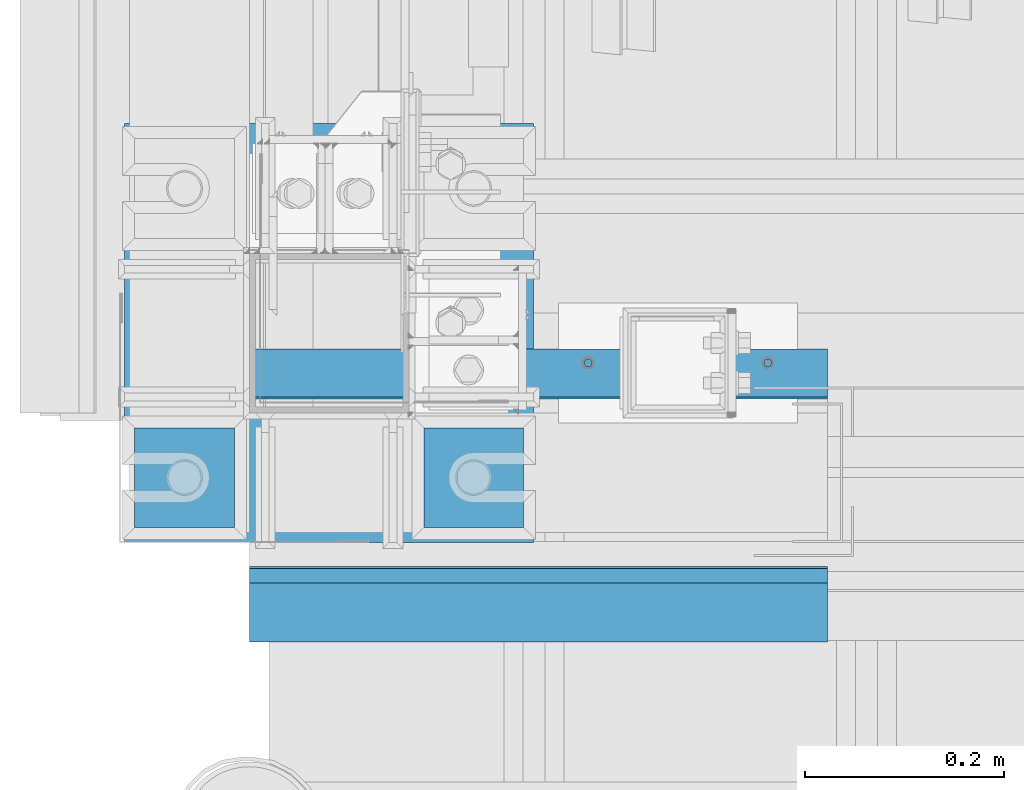
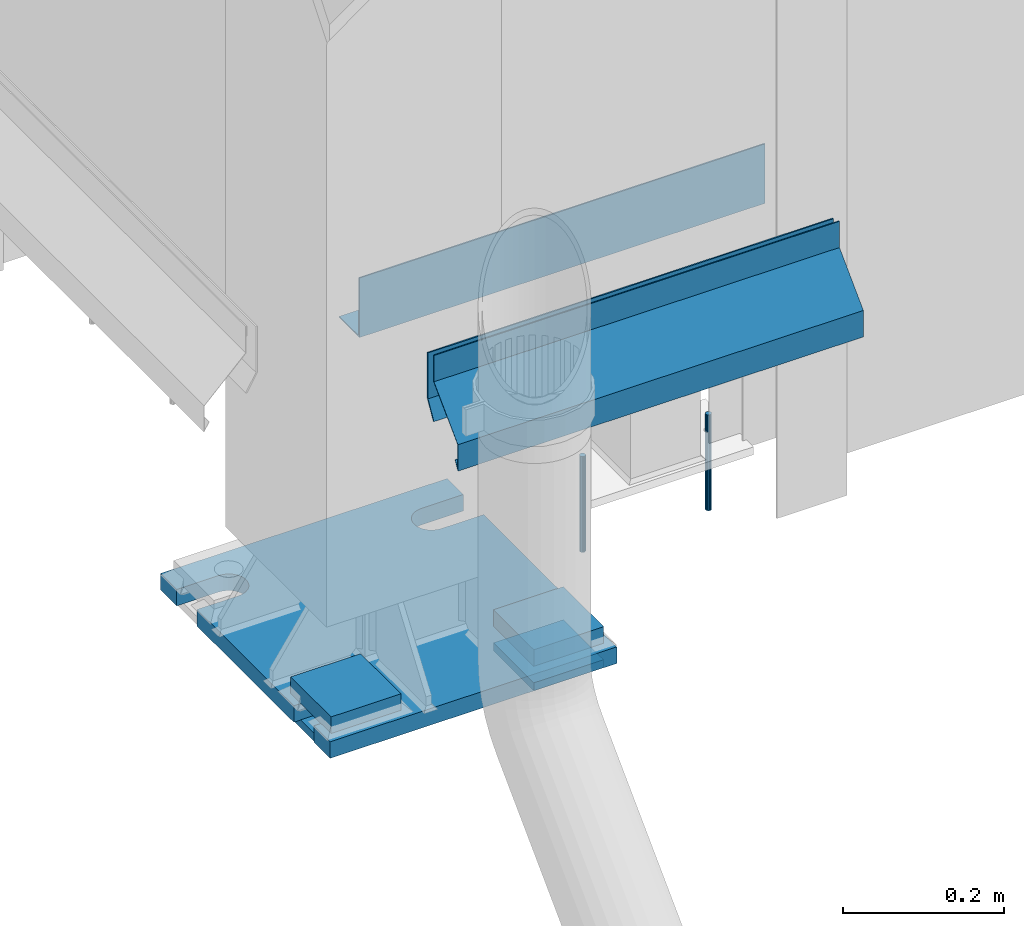
# One storey, part 82 of 709: 10 beams, 4 openings, 10 elements without a shape of their own.
"""IFC4 building model written with IfcOpenShell, lengths in millimetres."""

from ifc_helpers import new_model, si_unit, direction, frame, origin_with_axes, place, context, subcontext, project, spatial, line, arc, indexed_curve, outline, extrude, material, element, aggregate, save


model = new_model("IFC4")

# Units and contexts
model_context = context("Model", 3, precision=0.2, world=origin_with_axes(), true_north=direction((0.0, 1.0)))
body_context = subcontext(model_context, "Body", "Model", "MODEL_VIEW")
ifc_project = project(units=[si_unit("LENGTHUNIT", "METRE", prefix="MILLI"), si_unit("AREAUNIT", "SQUARE_METRE"), si_unit("VOLUMEUNIT", "CUBIC_METRE"), si_unit("MASSUNIT", "GRAM", prefix="KILO"), si_unit("TIMEUNIT", "SECOND"), si_unit("PLANEANGLEUNIT", "RADIAN"), si_unit("SOLIDANGLEUNIT", "STERADIAN"), si_unit("THERMODYNAMICTEMPERATUREUNIT", "DEGREE_CELSIUS"), si_unit("LUMINOUSINTENSITYUNIT", "LUMEN")], contexts=[model_context])

# Site, building, storey
site_placement = place(None, origin_with_axes())
site = spatial("IfcSite", under=ifc_project, at=site_placement, CompositionType="ELEMENT")
building_placement = place(site_placement, origin_with_axes())
building = spatial("IfcBuilding", under=site, at=building_placement, Name="Undefined", CompositionType="ELEMENT")
storey_placement = place(building_placement, origin_with_axes())
storey = spatial("IfcBuildingStorey", under=building, at=storey_placement, Name="Undefined", CompositionType="ELEMENT", Elevation=0.0)

# Assembly, beam, voiding features
assembly_1_placement = place(storey_placement, frame((80.0, 80.0, -200.0), z_axis=(0.0, -1.0, 0.0), x_axis=(0.0, 0.0, 1.0)))
assembly_1 = element("IfcElementAssembly", 1, at=assembly_1_placement, inside=storey)
ifc_material_1 = material(Name="C355-6", Category="STEEL")
beam_1_placement = place(assembly_1_placement, frame((12.5, 205.0, 0.0), z_axis=(-1.0, 0.0, 0.0), x_axis=(0.0, -1.0, 0.0)))
beam_1 = element("IfcBeam", 2, at=beam_1_placement, material=ifc_material_1, ObjectType="428", context=body_context, shape_type="SolidModel", body=[
    extrude(outline(indexed_curve([(-12.5, -210.0), (12.5, -210.0), (12.5, 210.0), (-12.5, 210.0)], segments=[line(1, 2, 3, 4, 1)])), frame((0.0, 0.0, 0.0), z_axis=(-1.0, 0.0, 0.0), x_axis=(0.0, 0.0, 1.0)), (0.0, 0.0, -1.0), 410.0),
])
voiding_feature_1_placement = place(beam_1_placement, frame((410.0, 170.0, 0.0), z_axis=(0.0, 0.0, -1.0), x_axis=(0.0, -1.0, 0.0)))
element("IfcVoidingFeature", 3, at=voiding_feature_1_placement, cuts=beam_1, PredefinedType="HOLE", context=body_context, shape_type="SolidModel", body=[
    extrude(outline(indexed_curve([(0.0, 0.0), (50.0, 0.0), (50.0, 60.0), (42.67767, 77.67767), (25.0, 85.0), (25.0, 85.0), (7.32233, 77.67767), (0.0, 60.0)], segments=[line(1, 2, 3), arc(3, 4, 5), line(5, 6), arc(6, 7, 8), line(8, 1)])), frame((0.0, 0.0, 12.5), z_axis=(0.0, 0.0, 1.0), x_axis=(1.0, 0.0, 0.0)), (0.0, 0.0, -1.0), 25.0),
])
voiding_feature_2_placement = place(beam_1_placement, frame((410.0, -120.0, 0.0), z_axis=(0.0, 0.0, -1.0), x_axis=(0.0, -1.0, 0.0)))
element("IfcVoidingFeature", 4, at=voiding_feature_2_placement, cuts=beam_1, PredefinedType="HOLE", context=body_context, shape_type="SolidModel", body=[
    extrude(outline(indexed_curve([(0.0, 0.0), (50.0, 0.0), (50.0, 60.0), (42.67767, 77.67767), (25.0, 85.0), (25.0, 85.0), (7.32233, 77.67767), (0.0, 60.0)], segments=[line(1, 2, 3), arc(3, 4, 5), line(5, 6), arc(6, 7, 8), line(8, 1)])), frame((0.0, 0.0, 12.5), z_axis=(0.0, 0.0, 1.0), x_axis=(1.0, 0.0, 0.0)), (0.0, 0.0, -1.0), 25.0),
])
voiding_feature_3_placement = place(beam_1_placement, frame((0.0, 120.0, 0.0), z_axis=(0.0, 0.0, -1.0), x_axis=(0.0, 1.0, 0.0)))
element("IfcVoidingFeature", 5, at=voiding_feature_3_placement, cuts=beam_1, PredefinedType="HOLE", context=body_context, shape_type="SolidModel", body=[
    extrude(outline(indexed_curve([(0.0, 0.0), (50.0, 0.0), (50.0, 60.0), (42.67767, 77.67767), (25.0, 85.0), (25.0, 85.0), (7.32233, 77.67767), (0.0, 60.0)], segments=[line(1, 2, 3), arc(3, 4, 5), line(5, 6), arc(6, 7, 8), line(8, 1)])), frame((0.0, 0.0, 12.5), z_axis=(0.0, 0.0, 1.0), x_axis=(1.0, 0.0, 0.0)), (0.0, 0.0, -1.0), 25.0),
])
voiding_feature_4_placement = place(beam_1_placement, frame((0.0, -170.0, 0.0), z_axis=(0.0, 0.0, -1.0), x_axis=(0.0, 1.0, 0.0)))
element("IfcVoidingFeature", 6, at=voiding_feature_4_placement, cuts=beam_1, PredefinedType="HOLE", context=body_context, shape_type="SolidModel", body=[
    extrude(outline(indexed_curve([(0.0, 0.0), (50.0, 0.0), (50.0, 60.0), (42.67767, 77.67767), (25.0, 85.0), (25.0, 85.0), (7.32233, 77.67767), (0.0, 60.0)], segments=[line(1, 2, 3), arc(3, 4, 5), line(5, 6), arc(6, 7, 8), line(8, 1)])), frame((0.0, 0.0, 12.5), z_axis=(0.0, 0.0, 1.0), x_axis=(1.0, 0.0, 0.0)), (0.0, 0.0, -1.0), 25.0),
])
aggregate(assembly_1, [beam_1])

# Assembly, beam
assembly_2_placement = place(storey_placement, frame((175.0, -65.0, -162.5), z_axis=(0.0, 0.0, -1.0), x_axis=(1.0, 0.0, 0.0)))
assembly_2 = element("IfcElementAssembly", 7, at=assembly_2_placement, inside=storey)
beam_2_placement = place(assembly_2_placement, origin_with_axes())
beam_2 = element("IfcBeam", 8, at=beam_2_placement, material=ifc_material_1, ObjectType="421", context=body_context, shape_type="SolidModel", body=[
    extrude(outline(indexed_curve([(-12.5, -50.0), (12.5, -50.0), (12.5, 50.0), (-12.5, 50.0)], segments=[line(1, 2, 3, 4, 1)])), frame((0.0, 0.0, 0.0), z_axis=(-1.0, 0.0, 0.0), x_axis=(0.0, 0.0, 1.0)), (0.0, 0.0, -1.0), 100.0),
])
aggregate(assembly_2, [beam_2])

assembly_3_placement = place(storey_placement, frame((175.0, -65.0, -206.0), z_axis=(0.0, 0.0, -1.0), x_axis=(1.0, 0.0, 0.0)))
assembly_3 = element("IfcElementAssembly", 9, at=assembly_3_placement, inside=storey)
beam_3_placement = place(assembly_3_placement, origin_with_axes())
beam_3 = element("IfcBeam", 10, at=beam_3_placement, material=ifc_material_1, ObjectType="422", context=body_context, shape_type="SolidModel", body=[
    extrude(outline(indexed_curve([(-6.0, -50.0), (6.0, -50.0), (6.0, 50.0), (-6.0, 50.0)], segments=[line(1, 2, 3, 4, 1)])), frame((0.0, 0.0, 0.0), z_axis=(-1.0, 0.0, 0.0), x_axis=(0.0, 0.0, 1.0)), (0.0, 0.0, -1.0), 100.0),
])
aggregate(assembly_3, [beam_3])

assembly_4_placement = place(storey_placement, frame((-115.0, -65.0, -162.5), z_axis=(0.0, 0.0, -1.0), x_axis=(1.0, 0.0, 0.0)))
assembly_4 = element("IfcElementAssembly", 11, at=assembly_4_placement, inside=storey)
beam_4_placement = place(assembly_4_placement, origin_with_axes())
beam_4 = element("IfcBeam", 12, at=beam_4_placement, material=ifc_material_1, ObjectType="421", context=body_context, shape_type="SolidModel", body=[
    extrude(outline(indexed_curve([(-12.5, -50.0), (12.5, -50.0), (12.5, 50.0), (-12.5, 50.0)], segments=[line(1, 2, 3, 4, 1)])), frame((0.0, 0.0, 0.0), z_axis=(-1.0, 0.0, 0.0), x_axis=(0.0, 0.0, 1.0)), (0.0, 0.0, -1.0), 100.0),
])
aggregate(assembly_4, [beam_4])

assembly_5_placement = place(storey_placement, frame((-115.0, -65.0, -206.0), z_axis=(0.0, 0.0, -1.0), x_axis=(1.0, 0.0, 0.0)))
assembly_5 = element("IfcElementAssembly", 13, at=assembly_5_placement, inside=storey)
beam_5_placement = place(assembly_5_placement, origin_with_axes())
beam_5 = element("IfcBeam", 14, at=beam_5_placement, material=ifc_material_1, ObjectType="422", context=body_context, shape_type="SolidModel", body=[
    extrude(outline(indexed_curve([(-6.0, -50.0), (6.0, -50.0), (6.0, 50.0), (-6.0, 50.0)], segments=[line(1, 2, 3, 4, 1)])), frame((0.0, 0.0, 0.0), z_axis=(-1.0, 0.0, 0.0), x_axis=(0.0, 0.0, 1.0)), (0.0, 0.0, -1.0), 100.0),
])
aggregate(assembly_5, [beam_5])

assembly_6_placement = place(storey_placement, frame((520.0, 50.0, -13.0), z_axis=(1.0, 0.0, 0.0), x_axis=(0.0, 0.0, -1.0)))
assembly_6 = element("IfcElementAssembly", 15, at=assembly_6_placement, inside=storey)
ifc_material_2 = material(Name="Steel_Undefined", Category="STEEL")
beam_6_placement = place(assembly_6_placement, origin_with_axes())
beam_6 = element("IfcBeam", 16, at=beam_6_placement, material=ifc_material_2, context=body_context, shape_type="SolidModel", body=[
    extrude(outline(indexed_curve([(4.0, 0.0), (3.69552, 1.53073), (2.82843, 2.82843), (1.53073, 3.69552), (0.0, 4.0), (-1.53073, 3.69552), (-2.82843, 2.82843), (-3.69552, 1.53073), (-4.0, 0.0), (-3.69552, -1.53073), (-2.82843, -2.82843), (-1.53073, -3.69552), (0.0, -4.0), (1.53073, -3.69552), (2.82843, -2.82843), (3.69552, -1.53073)], segments=[line(1, 2, 3, 4, 5, 6, 7, 8, 9, 10, 11, 12, 13, 14, 15, 16, 1)])), frame((0.0, 0.0, 0.0), z_axis=(-1.0, 0.0, 0.0), x_axis=(0.0, 0.0, 1.0)), (0.0, 0.0, -1.0), 145.0),
])
aggregate(assembly_6, [beam_6])

assembly_7_placement = place(storey_placement, frame((340.0, 50.0, -13.0), z_axis=(1.0, 0.0, 0.0), x_axis=(0.0, 0.0, -1.0)))
assembly_7 = element("IfcElementAssembly", 17, at=assembly_7_placement, inside=storey)
beam_7_placement = place(assembly_7_placement, origin_with_axes())
beam_7 = element("IfcBeam", 18, at=beam_7_placement, material=ifc_material_2, context=body_context, shape_type="SolidModel", body=[
    extrude(outline(indexed_curve([(4.0, 0.0), (3.69552, 1.53073), (2.82843, 2.82843), (1.53073, 3.69552), (0.0, 4.0), (-1.53073, 3.69552), (-2.82843, 2.82843), (-3.69552, 1.53073), (-4.0, 0.0), (-3.69552, -1.53073), (-2.82843, -2.82843), (-1.53073, -3.69552), (0.0, -4.0), (1.53073, -3.69552), (2.82843, -2.82843), (3.69552, -1.53073)], segments=[line(1, 2, 3, 4, 5, 6, 7, 8, 9, 10, 11, 12, 13, 14, 15, 16, 1)])), frame((0.0, 0.0, 0.0), z_axis=(-1.0, 0.0, 0.0), x_axis=(0.0, 0.0, 1.0)), (0.0, 0.0, -1.0), 145.0),
])
aggregate(assembly_7, [beam_7])

assembly_8_placement = place(storey_placement, frame((580.0, -170.375, 370.0), z_axis=(0.0, 1.0, 0.0), x_axis=(-1.0, 0.0, 0.0)))
assembly_8 = element("IfcElementAssembly", 19, at=assembly_8_placement, inside=storey)
beam_8_placement = place(assembly_8_placement, origin_with_axes())
beam_8 = element("IfcBeam", 20, at=beam_8_placement, material=ifc_material_2, context=body_context, shape_type="SolidModel", body=[
    extrude(outline(indexed_curve([(0.375, -20.0), (0.375, 19.25), (0.495, 19.25), (0.495, 5.0), (1.245, 5.0), (1.245, 20.0), (-0.375, 20.0), (-0.375, -19.68934), (-59.625, -78.93934), (-59.625, -118.93934), (-52.125, -105.94896), (-52.77452, -105.57396), (-58.875, -116.1403), (-58.875, -79.25)], segments=[line(1, 2, 3, 4, 5, 6, 7, 8, 9, 10, 11, 12, 13, 14, 1)])), frame((0.0, 0.0, 0.0), z_axis=(-1.0, 0.0, 0.0), x_axis=(0.0, 0.0, 1.0)), (0.0, 0.0, -1.0), 580.0),
])
aggregate(assembly_8, [beam_8])

assembly_9_placement = place(storey_placement, frame((0.0, -155.0, 350.0), z_axis=(0.0, 0.0, -1.0), x_axis=(1.0, 0.0, 0.0)))
assembly_9 = element("IfcElementAssembly", 21, at=assembly_9_placement, inside=storey)
beam_9_placement = place(assembly_9_placement, origin_with_axes())
beam_9 = element("IfcBeam", 22, at=beam_9_placement, material=ifc_material_2, context=body_context, shape_type="SolidModel", body=[
    extrude(outline(indexed_curve([(-35.0, -1.0), (35.0, -1.0), (60.98076, 14.0), (59.98076, 15.73205), (34.4641, 1.0), (-35.0, 1.0)], segments=[line(1, 2, 3, 4, 5, 6, 1)])), frame((0.0, 0.0, 0.0), z_axis=(-1.0, 0.0, 0.0), x_axis=(0.0, 0.0, 1.0)), (0.0, 0.0, -1.0), 580.0),
])
aggregate(assembly_9, [beam_9])

assembly_10_placement = place(storey_placement, frame((580.0, 15.0, 350.0), z_axis=(0.0, 0.0, -1.0), x_axis=(-1.0, 0.0, 0.0)))
assembly_10 = element("IfcElementAssembly", 23, at=assembly_10_placement, inside=storey)
beam_10_placement = place(assembly_10_placement, origin_with_axes())
beam_10 = element("IfcBeam", 24, at=beam_10_placement, material=ifc_material_2, context=body_context, shape_type="SolidModel", body=[
    extrude(outline(indexed_curve([(-45.0, -1.0), (45.0, -1.0), (45.0, 49.0), (43.0, 49.0), (43.0, 1.0), (-45.0, 1.0)], segments=[line(1, 2, 3, 4, 5, 6, 1)])), frame((0.0, 0.0, 0.0), z_axis=(-1.0, 0.0, 0.0), x_axis=(0.0, 0.0, 1.0)), (0.0, 0.0, -1.0), 580.0),
])
aggregate(assembly_10, [beam_10])

save(model, "model.ifc")
